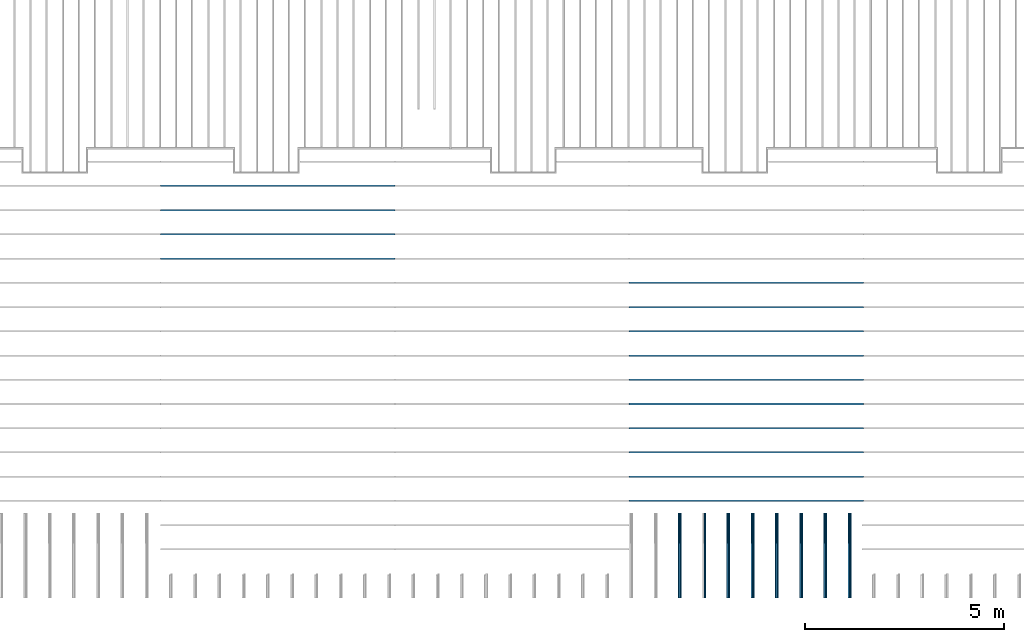
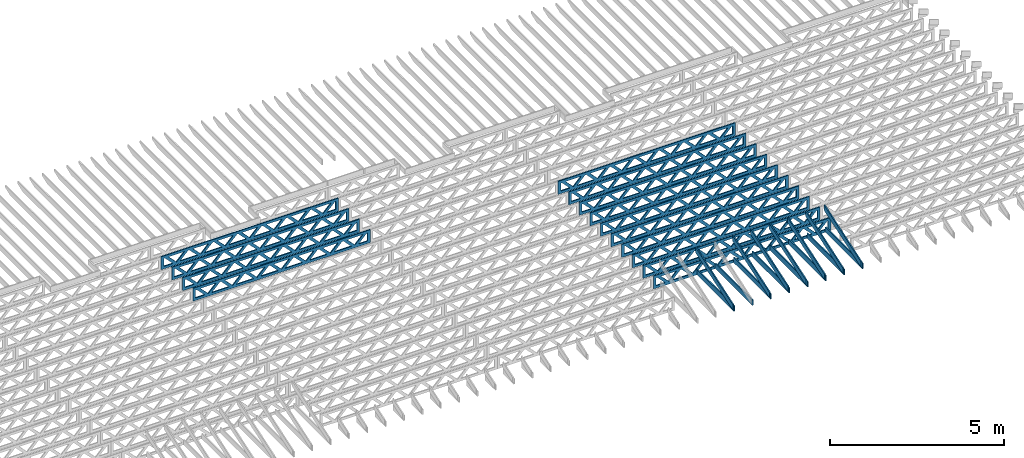
# One storey, part 8 of 18: 29 beams, 4 elements without a shape of their own.
"""IFC4 building model written with IfcOpenShell, lengths in feet."""

from ifc_helpers import new_model, entity, si_unit, converted_unit, derived_unit, direction, frame, frame_2d, origin, origin_2d_with_axis, place, context, subcontext, project, spatial, rectangle, extrude, clip, halfspace, source, transform, mapped, material, material_profile, profile_set, profile_usage, type_object, type_shapes, element, aggregate, save


model = new_model("IFC4")

# Units and contexts
model_context_1 = context("Model", 3, precision=0.0001, world=origin(), true_north=direction((6.12303176911189e-17, 1.0)))
model_context_2 = context("Model", 3, precision=0.0001, world=origin(), true_north=direction((6.12303176911189e-17, 1.0)))
body_context = subcontext(model_context_2, "Body", "Model", "MODEL_VIEW")
ifc_project = project(units=[converted_unit("LENGTHUNIT", "FOOT", entity("IfcRatioMeasure", 0.3048), si_unit("LENGTHUNIT", "METRE"), dimensions=[1, 0, 0, 0, 0, 0, 0]), converted_unit("AREAUNIT", "SQUARE FOOT", entity("IfcRatioMeasure", 0.09290304), si_unit("AREAUNIT", "SQUARE_METRE"), dimensions=[2, 0, 0, 0, 0, 0, 0]), converted_unit("VOLUMEUNIT", "CUBIC FOOT", entity("IfcRatioMeasure", 0.028316846592), si_unit("VOLUMEUNIT", "CUBIC_METRE"), dimensions=[3, 0, 0, 0, 0, 0, 0]), converted_unit("PLANEANGLEUNIT", "DEGREE", entity("IfcRatioMeasure", 0.0174532925199433), si_unit("PLANEANGLEUNIT", "RADIAN"), dimensions=[0, 0, 0, 0, 0, 0, 0]), si_unit("MASSUNIT", "GRAM", prefix="KILO"), derived_unit("MASSDENSITYUNIT", [(si_unit("MASSUNIT", "GRAM", prefix="KILO"), 1), (si_unit("LENGTHUNIT", "METRE"), -3)]), derived_unit("MOMENTOFINERTIAUNIT", [(si_unit("LENGTHUNIT", "METRE"), 4)]), si_unit("TIMEUNIT", "SECOND"), si_unit("FREQUENCYUNIT", "HERTZ"), si_unit("THERMODYNAMICTEMPERATUREUNIT", "DEGREE_CELSIUS"), derived_unit("THERMALTRANSMITTANCEUNIT", [(si_unit("MASSUNIT", "GRAM", prefix="KILO"), 1), (si_unit("THERMODYNAMICTEMPERATUREUNIT", "KELVIN"), -1), (si_unit("TIMEUNIT", "SECOND"), -3)]), derived_unit("VOLUMETRICFLOWRATEUNIT", [(si_unit("LENGTHUNIT", "METRE"), 3), (si_unit("TIMEUNIT", "SECOND"), -1)]), si_unit("ELECTRICCURRENTUNIT", "AMPERE"), si_unit("ELECTRICVOLTAGEUNIT", "VOLT"), si_unit("POWERUNIT", "WATT"), si_unit("FORCEUNIT", "NEWTON"), si_unit("ILLUMINANCEUNIT", "LUX"), si_unit("LUMINOUSFLUXUNIT", "LUMEN"), si_unit("LUMINOUSINTENSITYUNIT", "CANDELA"), derived_unit("USERDEFINED", [(si_unit("MASSUNIT", "GRAM", prefix="KILO"), -1), (si_unit("LENGTHUNIT", "METRE"), -2), (si_unit("TIMEUNIT", "SECOND"), 3), (si_unit("LUMINOUSFLUXUNIT", "LUMEN"), 1)]), derived_unit("LINEARVELOCITYUNIT", [(si_unit("LENGTHUNIT", "METRE"), 1), (si_unit("TIMEUNIT", "SECOND"), -1)]), si_unit("PRESSUREUNIT", "PASCAL"), derived_unit("USERDEFINED", [(si_unit("LENGTHUNIT", "METRE"), -2), (si_unit("MASSUNIT", "GRAM", prefix="KILO"), 1), (si_unit("TIMEUNIT", "SECOND"), -2)]), derived_unit("LINEARFORCEUNIT", [(si_unit("MASSUNIT", "GRAM", prefix="KILO"), 1), (si_unit("LENGTHUNIT", "METRE"), 1), (si_unit("TIMEUNIT", "SECOND"), -2), (si_unit("LENGTHUNIT", "METRE"), -1)]), derived_unit("PLANARFORCEUNIT", [(si_unit("MASSUNIT", "GRAM", prefix="KILO"), 1), (si_unit("LENGTHUNIT", "METRE"), 1), (si_unit("TIMEUNIT", "SECOND"), -2), (si_unit("LENGTHUNIT", "METRE"), -2)])], contexts=[model_context_1])

# Site, building, storey
site_placement = place(None, origin())
site = spatial("IfcSite", under=ifc_project, at=site_placement, CompositionType="ELEMENT")
building_placement = place(site_placement, origin())
building = spatial("IfcBuilding", under=site, at=building_placement, CompositionType="ELEMENT")
storey_placement = place(building_placement, frame((0.0, 0.0, 30.4375000000082)))
storey = spatial("IfcBuildingStorey", under=building, at=storey_placement, Name="ROOF", CompositionType="ELEMENT", Elevation=30.4375000000082)

# Assembly, beams
assembly_1_placement = place(storey_placement, origin())
assembly_1 = element("IfcElementAssembly", 1, at=assembly_1_placement, inside=storey, Name="Structural Beam System:Structural Framing System", ObjectType="Structural Beam System:Structural Framing System", AssemblyPlace="NOTDEFINED", PredefinedType="BEAM_GRID")
ifc_material_1 = material(Name="TOP CHORD OF FIELD FRAMED OVERHANG", Category="Materials")
ifc_material_profile_1 = material_profile(ifc_material_1, rectangle(XDim=0.604166666666667, YDim=0.125, at=origin_2d_with_axis()), Name="2X8 TOP CHORD")
ifc_profile_set_1 = profile_set([ifc_material_profile_1], Name="2X8 TOP CHORD")
ifc_profile_usage_1 = profile_usage(ifc_profile_set_1, cardinal=8)
beam_type_1 = type_object("IfcBeamType", Name="Dimension Lumber - Ends:2X8 TOP CHORD", PredefinedType="BEAM", material=ifc_profile_set_1)
shared_shape_1 = source(origin(), body_context, "Body", "Clipping", [
    clip(clip(extrude(rectangle(XDim=0.604166666666667, YDim=0.125, at=origin_2d_with_axis()), frame((-3.68931731846402, 0.0, 0.0), z_axis=(1.0, 0.0, 0.0), x_axis=(0.0, 0.0, -1.0)), (0.0, 0.0, 1.0), 7.5799655454405), halfspace(frame((3.68931731846399, -0.0625000000000025, -0.302083333333339), z_axis=(0.948710608132914, 0.0, -0.316145823973806), x_axis=(0.0, 1.0, 0.0)), False)), halfspace(frame((-3.48798640995154, -0.0625000000000025, 0.302083333333328), z_axis=(-0.948710608132914, 0.0, 0.316145823973807), x_axis=(0.0, 1.0, 0.0)), False)),
])
type_shapes(beam_type_1, [shared_shape_1])
beam_1_placement = place(assembly_1_placement, frame((-173.613158541547, 925.266385711858, 2.4368854134562), z_axis=(0.0, -0.316227766016849, 0.94868329805051), x_axis=(0.0, 0.94868329805051, 0.316227766016849)))
beam_1 = element("IfcBeam", 2, at=beam_1_placement, type_object=beam_type_1, material=ifc_profile_usage_1, Name="Dimension Lumber - Ends:2X8 TOP CHORD", ObjectType="Dimension Lumber - Ends:2X8 TOP CHORD", PredefinedType="BEAM", context=body_context, shape_type="MappedRepresentation", body=[
    mapped(shared_shape_1, transform((0.0, 0.0, 0.0), scale=1.0)),
])
ifc_profile_usage_2 = profile_usage(ifc_profile_set_1, cardinal=8)
beam_2_placement = place(assembly_1_placement, frame((-169.613158541547, 925.266385711858, 2.43688541345608), z_axis=(0.0, -0.316227766016849, 0.94868329805051), x_axis=(0.0, 0.94868329805051, 0.316227766016849)))
beam_2 = element("IfcBeam", 3, at=beam_2_placement, type_object=beam_type_1, material=ifc_profile_usage_2, Name="Dimension Lumber - Ends:2X8 TOP CHORD", ObjectType="Dimension Lumber - Ends:2X8 TOP CHORD", PredefinedType="BEAM", context=body_context, shape_type="MappedRepresentation", body=[
    mapped(shared_shape_1, transform((0.0, 0.0, 0.0), scale=1.0)),
])
ifc_profile_usage_3 = profile_usage(ifc_profile_set_1, cardinal=8)
beam_3_placement = place(assembly_1_placement, frame((-165.613158541547, 925.266385711858, 2.43688541345608), z_axis=(0.0, -0.31622776601685, 0.94868329805051), x_axis=(0.0, 0.94868329805051, 0.31622776601685)))
beam_3 = element("IfcBeam", 4, at=beam_3_placement, type_object=beam_type_1, material=ifc_profile_usage_3, Name="Dimension Lumber - Ends:2X8 TOP CHORD", ObjectType="Dimension Lumber - Ends:2X8 TOP CHORD", PredefinedType="BEAM", context=body_context, shape_type="MappedRepresentation", body=[
    mapped(shared_shape_1, transform((0.0, 0.0, 0.0), scale=1.0)),
])
ifc_profile_usage_4 = profile_usage(ifc_profile_set_1, cardinal=8)
beam_4_placement = place(assembly_1_placement, frame((-167.613158541547, 925.266385711858, 2.43688541345608), z_axis=(0.0, -0.316227766016849, 0.94868329805051), x_axis=(0.0, 0.94868329805051, 0.316227766016849)))
beam_4 = element("IfcBeam", 5, at=beam_4_placement, type_object=beam_type_1, material=ifc_profile_usage_4, Name="Dimension Lumber - Ends:2X8 TOP CHORD", ObjectType="Dimension Lumber - Ends:2X8 TOP CHORD", PredefinedType="BEAM", context=body_context, shape_type="MappedRepresentation", body=[
    mapped(shared_shape_1, transform((0.0, 0.0, 0.0), scale=1.0)),
])
ifc_profile_usage_5 = profile_usage(ifc_profile_set_1, cardinal=8)
beam_5_placement = place(assembly_1_placement, frame((-171.613158541547, 925.266385711858, 2.43688541345614), z_axis=(0.0, -0.31622776601685, 0.94868329805051), x_axis=(0.0, 0.94868329805051, 0.31622776601685)))
beam_5 = element("IfcBeam", 6, at=beam_5_placement, type_object=beam_type_1, material=ifc_profile_usage_5, Name="Dimension Lumber - Ends:2X8 TOP CHORD", ObjectType="Dimension Lumber - Ends:2X8 TOP CHORD", PredefinedType="BEAM", context=body_context, shape_type="MappedRepresentation", body=[
    mapped(shared_shape_1, transform((0.0, 0.0, 0.0), scale=1.0)),
])
ifc_profile_usage_6 = profile_usage(ifc_profile_set_1, cardinal=8)
beam_6_placement = place(assembly_1_placement, frame((-175.613158541547, 925.266385711858, 2.43688541345614), z_axis=(0.0, -0.316227766016849, 0.94868329805051), x_axis=(0.0, 0.94868329805051, 0.316227766016849)))
beam_6 = element("IfcBeam", 7, at=beam_6_placement, type_object=beam_type_1, material=ifc_profile_usage_6, Name="Dimension Lumber - Ends:2X8 TOP CHORD", ObjectType="Dimension Lumber - Ends:2X8 TOP CHORD", PredefinedType="BEAM", context=body_context, shape_type="MappedRepresentation", body=[
    mapped(shared_shape_1, transform((0.0, 0.0, 0.0), scale=1.0)),
])
ifc_profile_usage_7 = profile_usage(ifc_profile_set_1, cardinal=8)
beam_7_placement = place(assembly_1_placement, frame((-179.613158541548, 925.266385711858, 2.4368854134562), z_axis=(0.0, -0.316227766016853, 0.948683298050509), x_axis=(0.0, 0.948683298050509, 0.316227766016853)))
beam_7 = element("IfcBeam", 8, at=beam_7_placement, type_object=beam_type_1, material=ifc_profile_usage_7, Name="Dimension Lumber - Ends:2X8 TOP CHORD", ObjectType="Dimension Lumber - Ends:2X8 TOP CHORD", PredefinedType="BEAM", context=body_context, shape_type="MappedRepresentation", body=[
    mapped(shared_shape_1, transform((0.0, 0.0, 0.0), scale=1.0)),
])
aggregate(assembly_1, [beam_1, beam_2, beam_3, beam_4, beam_5, beam_6, beam_7])

assembly_2_placement = place(storey_placement, origin())
assembly_2 = element("IfcElementAssembly", 9, at=assembly_2_placement, inside=storey, Name="Structural Beam System:Structural Framing System", ObjectType="Structural Beam System:Structural Framing System", AssemblyPlace="NOTDEFINED", PredefinedType="BEAM_GRID")
ifc_material_2 = material(Name="BOTTOM CHORD OF FIELD FRAMED OVERHANG", Category="Materials")
ifc_material_profile_2 = material_profile(ifc_material_2, rectangle(XDim=0.604166666666667, YDim=0.125000000000011, at=origin_2d_with_axis()), Name="2X8 - BOTTOM CHORD")
ifc_profile_set_2 = profile_set([ifc_material_profile_2], Name="2X8 - BOTTOM CHORD")
ifc_profile_usage_8 = profile_usage(ifc_profile_set_2, cardinal=8)
beam_type_2 = type_object("IfcBeamType", Name="061100 - Wood Framing:2X8 - BOTTOM CHORD", PredefinedType="BEAM", material=ifc_profile_set_2)
shared_shape_2 = source(origin(), body_context, "Body", "SweptSolid", [
    extrude(rectangle(XDim=0.604166666666667, YDim=0.125000000000011, at=origin_2d_with_axis()), frame((-3.49999999999926, 0.0, 0.0), z_axis=(1.0, 0.0, 0.0), x_axis=(0.0, 0.0, -1.0)), (0.0, 0.0, 1.0), 6.99999999999852),
])
type_shapes(beam_type_2, [shared_shape_2])
beam_8_placement = place(assembly_2_placement, frame((-179.488158437574, 925.361940807891, 1.07291666665406), z_axis=(0.0, 0.0, 1.0), x_axis=(0.0, -1.0, 0.0)))
beam_8 = element("IfcBeam", 10, at=beam_8_placement, type_object=beam_type_2, material=ifc_profile_usage_8, Name="061100 - Wood Framing:2X8 - BOTTOM CHORD", ObjectType="061100 - Wood Framing:2X8 - BOTTOM CHORD", PredefinedType="BEAM", context=body_context, shape_type="MappedRepresentation", body=[
    mapped(shared_shape_2, transform((0.0, 0.0, 0.0), scale=1.0)),
])
ifc_profile_usage_9 = profile_usage(ifc_profile_set_2, cardinal=8)
beam_9_placement = place(assembly_2_placement, frame((-175.488158437574, 925.361941812898, 1.07291666665406), z_axis=(0.0, 0.0, 1.0), x_axis=(0.0, -1.0, 0.0)))
beam_9 = element("IfcBeam", 11, at=beam_9_placement, type_object=beam_type_2, material=ifc_profile_usage_9, Name="061100 - Wood Framing:2X8 - BOTTOM CHORD", ObjectType="061100 - Wood Framing:2X8 - BOTTOM CHORD", PredefinedType="BEAM", context=body_context, shape_type="MappedRepresentation", body=[
    mapped(shared_shape_2, transform((0.0, 0.0, 0.0), scale=1.0)),
])
ifc_profile_usage_10 = profile_usage(ifc_profile_set_2, cardinal=8)
beam_10_placement = place(assembly_2_placement, frame((-173.488158437574, 925.361942315402, 1.07291666665406), z_axis=(0.0, 0.0, 1.0), x_axis=(0.0, -1.0, 0.0)))
beam_10 = element("IfcBeam", 12, at=beam_10_placement, type_object=beam_type_2, material=ifc_profile_usage_10, Name="061100 - Wood Framing:2X8 - BOTTOM CHORD", ObjectType="061100 - Wood Framing:2X8 - BOTTOM CHORD", PredefinedType="BEAM", context=body_context, shape_type="MappedRepresentation", body=[
    mapped(shared_shape_2, transform((0.0, 0.0, 0.0), scale=1.0)),
])
ifc_profile_usage_11 = profile_usage(ifc_profile_set_2, cardinal=8)
beam_11_placement = place(assembly_2_placement, frame((-171.488158437574, 925.361942817905, 1.07291666665406), z_axis=(0.0, 0.0, 1.0), x_axis=(0.0, -1.0, 0.0)))
beam_11 = element("IfcBeam", 13, at=beam_11_placement, type_object=beam_type_2, material=ifc_profile_usage_11, Name="061100 - Wood Framing:2X8 - BOTTOM CHORD", ObjectType="061100 - Wood Framing:2X8 - BOTTOM CHORD", PredefinedType="BEAM", context=body_context, shape_type="MappedRepresentation", body=[
    mapped(shared_shape_2, transform((0.0, 0.0, 0.0), scale=1.0)),
])
ifc_profile_usage_12 = profile_usage(ifc_profile_set_2, cardinal=8)
beam_12_placement = place(assembly_2_placement, frame((-165.488158437574, 925.361944325417, 1.07291666665406), z_axis=(0.0, 0.0, 1.0), x_axis=(0.0, -1.0, 0.0)))
beam_12 = element("IfcBeam", 14, at=beam_12_placement, type_object=beam_type_2, material=ifc_profile_usage_12, Name="061100 - Wood Framing:2X8 - BOTTOM CHORD", ObjectType="061100 - Wood Framing:2X8 - BOTTOM CHORD", PredefinedType="BEAM", context=body_context, shape_type="MappedRepresentation", body=[
    mapped(shared_shape_2, transform((0.0, 0.0, 0.0), scale=1.0)),
])
ifc_profile_usage_13 = profile_usage(ifc_profile_set_2, cardinal=8)
beam_13_placement = place(assembly_2_placement, frame((-167.488158437574, 925.361943822913, 1.07291666665406), z_axis=(0.0, 0.0, 1.0), x_axis=(0.0, -1.0, 0.0)))
beam_13 = element("IfcBeam", 15, at=beam_13_placement, type_object=beam_type_2, material=ifc_profile_usage_13, Name="061100 - Wood Framing:2X8 - BOTTOM CHORD", ObjectType="061100 - Wood Framing:2X8 - BOTTOM CHORD", PredefinedType="BEAM", context=body_context, shape_type="MappedRepresentation", body=[
    mapped(shared_shape_2, transform((0.0, 0.0, 0.0), scale=1.0)),
])
ifc_profile_usage_14 = profile_usage(ifc_profile_set_2, cardinal=8)
beam_14_placement = place(assembly_2_placement, frame((-169.488158437574, 925.361943320409, 1.07291666665406), z_axis=(0.0, 0.0, 1.0), x_axis=(0.0, -1.0, 0.0)))
beam_14 = element("IfcBeam", 16, at=beam_14_placement, type_object=beam_type_2, material=ifc_profile_usage_14, Name="061100 - Wood Framing:2X8 - BOTTOM CHORD", ObjectType="061100 - Wood Framing:2X8 - BOTTOM CHORD", PredefinedType="BEAM", context=body_context, shape_type="MappedRepresentation", body=[
    mapped(shared_shape_2, transform((0.0, 0.0, 0.0), scale=1.0)),
])
ifc_profile_usage_15 = profile_usage(ifc_profile_set_2, cardinal=8)
beam_15_placement = place(assembly_2_placement, frame((-177.488158437574, 925.361941310394, 1.07291666665406), z_axis=(0.0, 0.0, 1.0), x_axis=(0.0, -1.0, 0.0)))
beam_15 = element("IfcBeam", 17, at=beam_15_placement, type_object=beam_type_2, material=ifc_profile_usage_15, Name="061100 - Wood Framing:2X8 - BOTTOM CHORD", ObjectType="061100 - Wood Framing:2X8 - BOTTOM CHORD", PredefinedType="BEAM", context=body_context, shape_type="MappedRepresentation", body=[
    mapped(shared_shape_2, transform((0.0, 0.0, 0.0), scale=1.0)),
])
aggregate(assembly_2, [beam_8, beam_9, beam_10, beam_11, beam_12, beam_13, beam_14, beam_15])

assembly_3_placement = place(storey_placement, origin())
assembly_3 = element("IfcElementAssembly", 18, at=assembly_3_placement, inside=storey, Name="Structural Beam System:Structural Framing System", ObjectType="Structural Beam System:Structural Framing System", AssemblyPlace="NOTDEFINED", PredefinedType="BEAM_GRID")
ifc_material_3 = material(Name="WOOD TRUSS", Category="Materials")
ifc_material_profile_3 = material_profile(ifc_material_3, rectangle(XDim=1.73473973950632, YDim=0.125, at=origin_2d_with_axis()))
ifc_material_profile_4 = material_profile(ifc_material_3, rectangle(XDim=1.73473973950633, YDim=0.125, at=frame_2d((-1.11022302462516e-16, 0.0), x_axis=(1.0, 0.0))))
ifc_material_profile_5 = material_profile(ifc_material_3, rectangle(XDim=1.73473973950632, YDim=0.125, at=origin_2d_with_axis()))
ifc_material_profile_6 = material_profile(ifc_material_3, rectangle(XDim=1.73473973950633, YDim=0.125, at=origin_2d_with_axis()))
ifc_material_profile_7 = material_profile(ifc_material_3, rectangle(XDim=1.73473973950632, YDim=0.125, at=frame_2d((-5.55111512312578e-17, 0.0), x_axis=(1.0, 0.0))))
ifc_material_profile_8 = material_profile(ifc_material_3, rectangle(XDim=1.73473973950633, YDim=0.125, at=frame_2d((-2.77555756156289e-16, 0.0), x_axis=(1.0, 0.0))))
ifc_material_profile_9 = material_profile(ifc_material_3, rectangle(XDim=1.73473973950632, YDim=0.125, at=frame_2d((-4.9960036108132e-16, 0.0), x_axis=(1.0, 0.0))))
ifc_material_profile_10 = material_profile(ifc_material_3, rectangle(XDim=1.73473973950633, YDim=0.125, at=frame_2d((4.44089209850063e-16, 0.0), x_axis=(1.0, 0.0))))
ifc_material_profile_11 = material_profile(ifc_material_3, rectangle(XDim=1.73473973950632, YDim=0.125, at=origin_2d_with_axis()))
ifc_material_profile_12 = material_profile(ifc_material_3, rectangle(XDim=1.73473973950633, YDim=0.125, at=frame_2d((-4.9960036108132e-16, 0.0), x_axis=(1.0, 0.0))))
ifc_material_profile_13 = material_profile(ifc_material_3, rectangle(XDim=0.291666666666664, YDim=0.125, at=frame_2d((-2.77555756156289e-17, 0.0), x_axis=(1.0, 0.0))))
ifc_material_profile_14 = material_profile(ifc_material_3, rectangle(XDim=0.291666666666628, YDim=0.124999999999995, at=frame_2d((-5.55111512312578e-17, 0.0), x_axis=(1.0, 0.0))))
ifc_material_profile_15 = material_profile(ifc_material_3, rectangle(XDim=0.916666666666666, YDim=0.125000000000003, at=frame_2d((-2.77555756156289e-17, 0.0), x_axis=(1.0, 0.0))))
ifc_material_profile_16 = material_profile(ifc_material_3, rectangle(XDim=0.916666666666651, YDim=0.125, at=frame_2d((-2.77555756156289e-17, 0.0), x_axis=(1.0, 0.0))))
ifc_profile_set_3 = profile_set([ifc_material_profile_3, ifc_material_profile_4, ifc_material_profile_5, ifc_material_profile_6, ifc_material_profile_7, ifc_material_profile_8, ifc_material_profile_9, ifc_material_profile_10, ifc_material_profile_11, ifc_material_profile_12, ifc_material_profile_13, ifc_material_profile_14, ifc_material_profile_15, ifc_material_profile_16])
ifc_profile_usage_16 = profile_usage(ifc_profile_set_3, cardinal=8)
beam_type_3 = type_object("IfcBeamType", PredefinedType="BEAM", material=ifc_profile_set_3)
shared_shape_3 = source(origin(), body_context, "Body", "SweptSolid", [
    extrude(rectangle(XDim=1.73473973950632, YDim=0.125, at=frame_2d((-5.55111512312578e-16, 0.0), x_axis=(1.0, 0.0))), frame((5.85339326404794, 0.0, 0.101118361020562), z_axis=(0.720569184836762, 0.0, -0.693383046997606), x_axis=(0.693383046997606, 0.0, 0.720569184836762)), (0.0, 0.0, 1.0), 0.291666666666667),
    extrude(rectangle(XDim=1.73473973950633, YDim=0.125, at=frame_2d((-4.9960036108132e-16, 0.0), x_axis=(1.0, 0.0))), frame((4.60310739037467, 0.0, -0.101118361020407), z_axis=(0.720569184836758, 0.0, 0.69338304699761), x_axis=(0.69338304699761, 0.0, -0.720569184836758)), (0.0, 0.0, 1.0), 0.291666666666667),
    extrude(rectangle(XDim=1.73473973950632, YDim=0.125, at=frame_2d((3.33066907387547e-16, 0.0), x_axis=(1.0, 0.0))), frame((3.18672659738144, 0.0, 0.101118361020562), z_axis=(0.720569184836762, 0.0, -0.693383046997606), x_axis=(0.693383046997606, 0.0, 0.720569184836762)), (0.0, 0.0, 1.0), 0.291666666666667),
    extrude(rectangle(XDim=1.73473973950633, YDim=0.125, at=frame_2d((-1.11022302462516e-16, 0.0), x_axis=(1.0, 0.0))), frame((1.93644072370817, 0.0, -0.101118361020407), z_axis=(0.720569184836758, 0.0, 0.69338304699761), x_axis=(0.69338304699761, 0.0, -0.720569184836758)), (0.0, 0.0, 1.0), 0.291666666666666),
    extrude(rectangle(XDim=1.73473973950632, YDim=0.125, at=frame_2d((5.55111512312578e-17, 0.0), x_axis=(1.0, 0.0))), frame((0.520059930714937, 0.0, 0.101118361020562), z_axis=(0.720569184836762, 0.0, -0.693383046997606), x_axis=(0.693383046997606, 0.0, 0.720569184836762)), (0.0, 0.0, 1.0), 0.291666666666667),
    extrude(rectangle(XDim=1.73473973950633, YDim=0.125, at=origin_2d_with_axis()), frame((-0.730225942958334, 0.0, -0.101118361020407), z_axis=(0.720569184836758, 0.0, 0.69338304699761), x_axis=(0.69338304699761, 0.0, -0.720569184836758)), (0.0, 0.0, 1.0), 0.291666666666666),
    extrude(rectangle(XDim=1.73473973950632, YDim=0.125, at=frame_2d((-5.55111512312578e-17, 0.0), x_axis=(1.0, 0.0))), frame((-2.14660673595157, 0.0, 0.101118361020562), z_axis=(0.720569184836762, 0.0, -0.693383046997606), x_axis=(0.693383046997606, 0.0, 0.720569184836762)), (0.0, 0.0, 1.0), 0.291666666666667),
    extrude(rectangle(XDim=1.73473973950633, YDim=0.125, at=frame_2d((-2.77555756156289e-16, 0.0), x_axis=(1.0, 0.0))), frame((-3.39689260962484, 0.0, -0.101118361020407), z_axis=(0.720569184836758, 0.0, 0.69338304699761), x_axis=(0.69338304699761, 0.0, -0.720569184836758)), (0.0, 0.0, 1.0), 0.291666666666666),
    extrude(rectangle(XDim=1.73473973950632, YDim=0.125, at=origin_2d_with_axis()), frame((-4.81327340261807, 0.0, 0.101118361020562), z_axis=(0.720569184836762, 0.0, -0.693383046997606), x_axis=(0.693383046997606, 0.0, 0.720569184836762)), (0.0, 0.0, 1.0), 0.291666666666667),
    extrude(rectangle(XDim=1.73473973950633, YDim=0.125, at=frame_2d((-4.9960036108132e-16, 0.0), x_axis=(1.0, 0.0))), frame((-6.06355927629134, 0.0, -0.101118361020407), z_axis=(0.720569184836758, 0.0, 0.69338304699761), x_axis=(0.69338304699761, 0.0, -0.720569184836758)), (0.0, 0.0, 1.0), 0.291666666666667),
    extrude(rectangle(XDim=1.73473973950632, YDim=0.125, at=frame_2d((-1.0547118733939e-15, 0.0), x_axis=(1.0, 0.0))), frame((8.52005993071445, 0.0, 0.101118361020506), z_axis=(0.720569184836761, 0.0, -0.693383046997607), x_axis=(0.693383046997607, 0.0, 0.720569184836761)), (0.0, 0.0, 1.0), 0.291666666666667),
    extrude(rectangle(XDim=1.73473973950633, YDim=0.125, at=origin_2d_with_axis()), frame((7.26977405704118, 0.0, -0.101118361020463), z_axis=(0.720569184836758, 0.0, 0.69338304699761), x_axis=(0.69338304699761, 0.0, -0.720569184836758)), (0.0, 0.0, 1.0), 0.291666666666667),
    extrude(rectangle(XDim=1.73473973950632, YDim=0.125, at=frame_2d((4.44089209850063e-16, 0.0), x_axis=(1.0, 0.0))), frame((-7.47994006928457, 0.0, 0.101118361020561), z_axis=(0.720569184836762, 0.0, -0.693383046997606), x_axis=(0.693383046997606, 0.0, 0.720569184836762)), (0.0, 0.0, 1.0), 0.291666666666666),
    extrude(rectangle(XDim=1.73473973950633, YDim=0.125, at=origin_2d_with_axis()), frame((-8.73022594295784, 0.0, -0.101118361020408), z_axis=(0.720569184836758, 0.0, 0.69338304699761), x_axis=(0.69338304699761, 0.0, -0.720569184836758)), (0.0, 0.0, 1.0), 0.291666666666666),
    extrude(rectangle(XDim=0.291666666666664, YDim=0.125, at=frame_2d((-2.77555756156289e-17, 0.0), x_axis=(1.0, 0.0))), frame((-9.66666666666609, 0.0, 0.604166666666611), z_axis=(1.0, 0.0, 0.0), x_axis=(0.0, 0.0, -1.0)), (0.0, 0.0, 1.0), 19.3333333333322),
    extrude(rectangle(XDim=0.291666666666628, YDim=0.124999999999995, at=frame_2d((-5.55111512312578e-17, 0.0), x_axis=(1.0, 0.0))), frame((-9.66666666666588, 0.0, -0.604166666666693), z_axis=(1.0, 0.0, 0.0), x_axis=(0.0, 0.0, -1.0)), (0.0, 0.0, 1.0), 19.333333333332),
    extrude(rectangle(XDim=0.916666666666666, YDim=0.125000000000003, at=frame_2d((-2.77555756156289e-17, 0.0), x_axis=(1.0, 0.0))), frame((9.3749999999994, 0.0, 0.0), z_axis=(1.0, 0.0, 0.0), x_axis=(0.0, 0.0, -1.0)), (0.0, 0.0, 1.0), 0.291666666666687),
    extrude(rectangle(XDim=0.916666666666651, YDim=0.125, at=frame_2d((-2.77555756156289e-17, 0.0), x_axis=(1.0, 0.0))), frame((-9.66666666666609, 0.0, 0.0), z_axis=(1.0, 0.0, 0.0), x_axis=(0.0, 0.0, -1.0)), (0.0, 0.0, 1.0), 0.291666666666687),
])
type_shapes(beam_type_3, [shared_shape_3])
beam_16_placement = place(assembly_3_placement, frame((-212.738160485494, 949.861934882651, 0.749999999991616), z_axis=(0.0, 0.0, 1.0), x_axis=(-1.0, 0.0, 0.0)))
beam_16 = element("IfcBeam", 19, at=beam_16_placement, type_object=beam_type_3, material=ifc_profile_usage_16, PredefinedType="BEAM", context=body_context, shape_type="MappedRepresentation", body=[
    mapped(shared_shape_3, transform((0.0, 0.0, 0.0), scale=1.0)),
])
ifc_profile_usage_17 = profile_usage(ifc_profile_set_3, cardinal=8)
beam_17_placement = place(assembly_3_placement, frame((-212.738160485494, 951.861934882651, 0.749999999991608), z_axis=(0.0, 0.0, 1.0), x_axis=(-1.0, 0.0, 0.0)))
beam_17 = element("IfcBeam", 20, at=beam_17_placement, type_object=beam_type_3, material=ifc_profile_usage_17, PredefinedType="BEAM", context=body_context, shape_type="MappedRepresentation", body=[
    mapped(shared_shape_3, transform((0.0, 0.0, 0.0), scale=1.0)),
])
ifc_profile_usage_18 = profile_usage(ifc_profile_set_3, cardinal=8)
beam_18_placement = place(assembly_3_placement, frame((-212.738160485494, 953.861934882651, 0.749999999991601), z_axis=(0.0, 0.0, 1.0), x_axis=(-1.0, 0.0, 0.0)))
beam_18 = element("IfcBeam", 21, at=beam_18_placement, type_object=beam_type_3, material=ifc_profile_usage_18, PredefinedType="BEAM", context=body_context, shape_type="MappedRepresentation", body=[
    mapped(shared_shape_3, transform((0.0, 0.0, 0.0), scale=1.0)),
])
ifc_profile_usage_19 = profile_usage(ifc_profile_set_3, cardinal=8)
beam_19_placement = place(assembly_3_placement, frame((-212.738160485494, 955.861934882651, 0.749999999991601), z_axis=(0.0, 0.0, 1.0), x_axis=(-1.0, 0.0, 0.0)))
beam_19 = element("IfcBeam", 22, at=beam_19_placement, type_object=beam_type_3, material=ifc_profile_usage_19, PredefinedType="BEAM", context=body_context, shape_type="MappedRepresentation", body=[
    mapped(shared_shape_3, transform((0.0, 0.0, 0.0), scale=1.0)),
])
aggregate(assembly_3, [beam_16, beam_17, beam_18, beam_19])

assembly_4_placement = place(storey_placement, origin())
assembly_4 = element("IfcElementAssembly", 23, at=assembly_4_placement, inside=storey, Name="Structural Beam System:Structural Framing System", ObjectType="Structural Beam System:Structural Framing System", AssemblyPlace="NOTDEFINED", PredefinedType="BEAM_GRID")
ifc_profile_usage_20 = profile_usage(ifc_profile_set_3, cardinal=8)
beam_20_placement = place(assembly_4_placement, frame((-174.071493818896, 929.861934882651, 0.74999999999168), z_axis=(0.0, 0.0, 1.0), x_axis=(-1.0, 0.0, 0.0)))
beam_20 = element("IfcBeam", 24, at=beam_20_placement, type_object=beam_type_3, material=ifc_profile_usage_20, PredefinedType="BEAM", context=body_context, shape_type="MappedRepresentation", body=[
    mapped(shared_shape_3, transform((0.0, 0.0, 0.0), scale=1.0)),
])
ifc_profile_usage_21 = profile_usage(ifc_profile_set_3, cardinal=8)
beam_21_placement = place(assembly_4_placement, frame((-174.071493818896, 931.861934882651, 0.74999999999168), z_axis=(0.0, 0.0, 1.0), x_axis=(-1.0, 0.0, 0.0)))
beam_21 = element("IfcBeam", 25, at=beam_21_placement, type_object=beam_type_3, material=ifc_profile_usage_21, PredefinedType="BEAM", context=body_context, shape_type="MappedRepresentation", body=[
    mapped(shared_shape_3, transform((0.0, 0.0, 0.0), scale=1.0)),
])
ifc_profile_usage_22 = profile_usage(ifc_profile_set_3, cardinal=8)
beam_22_placement = place(assembly_4_placement, frame((-174.071493818896, 933.861934882651, 0.749999999991672), z_axis=(0.0, 0.0, 1.0), x_axis=(-1.0, 0.0, 0.0)))
beam_22 = element("IfcBeam", 26, at=beam_22_placement, type_object=beam_type_3, material=ifc_profile_usage_22, PredefinedType="BEAM", context=body_context, shape_type="MappedRepresentation", body=[
    mapped(shared_shape_3, transform((0.0, 0.0, 0.0), scale=1.0)),
])
ifc_profile_usage_23 = profile_usage(ifc_profile_set_3, cardinal=8)
beam_23_placement = place(assembly_4_placement, frame((-174.071493818896, 935.861934882651, 0.749999999991665), z_axis=(0.0, 0.0, 1.0), x_axis=(-1.0, 0.0, 0.0)))
beam_23 = element("IfcBeam", 27, at=beam_23_placement, type_object=beam_type_3, material=ifc_profile_usage_23, PredefinedType="BEAM", context=body_context, shape_type="MappedRepresentation", body=[
    mapped(shared_shape_3, transform((0.0, 0.0, 0.0), scale=1.0)),
])
ifc_profile_usage_24 = profile_usage(ifc_profile_set_3, cardinal=8)
beam_24_placement = place(assembly_4_placement, frame((-174.071493818896, 937.861934882651, 0.749999999991658), z_axis=(0.0, 0.0, 1.0), x_axis=(-1.0, 0.0, 0.0)))
beam_24 = element("IfcBeam", 28, at=beam_24_placement, type_object=beam_type_3, material=ifc_profile_usage_24, PredefinedType="BEAM", context=body_context, shape_type="MappedRepresentation", body=[
    mapped(shared_shape_3, transform((0.0, 0.0, 0.0), scale=1.0)),
])
ifc_profile_usage_25 = profile_usage(ifc_profile_set_3, cardinal=8)
beam_25_placement = place(assembly_4_placement, frame((-174.071493818896, 939.861934882651, 0.749999999991651), z_axis=(0.0, 0.0, 1.0), x_axis=(-1.0, 0.0, 0.0)))
beam_25 = element("IfcBeam", 29, at=beam_25_placement, type_object=beam_type_3, material=ifc_profile_usage_25, PredefinedType="BEAM", context=body_context, shape_type="MappedRepresentation", body=[
    mapped(shared_shape_3, transform((0.0, 0.0, 0.0), scale=1.0)),
])
ifc_profile_usage_26 = profile_usage(ifc_profile_set_3, cardinal=8)
beam_26_placement = place(assembly_4_placement, frame((-174.071493818896, 943.861934882651, 0.749999999991644), z_axis=(0.0, 0.0, 1.0), x_axis=(-1.0, 0.0, 0.0)))
beam_26 = element("IfcBeam", 30, at=beam_26_placement, type_object=beam_type_3, material=ifc_profile_usage_26, PredefinedType="BEAM", context=body_context, shape_type="MappedRepresentation", body=[
    mapped(shared_shape_3, transform((0.0, 0.0, 0.0), scale=1.0)),
])
ifc_profile_usage_27 = profile_usage(ifc_profile_set_3, cardinal=8)
beam_27_placement = place(assembly_4_placement, frame((-174.071493818896, 947.861934882651, 0.74999999999163), z_axis=(0.0, 0.0, 1.0), x_axis=(-1.0, 0.0, 0.0)))
beam_27 = element("IfcBeam", 31, at=beam_27_placement, type_object=beam_type_3, material=ifc_profile_usage_27, PredefinedType="BEAM", context=body_context, shape_type="MappedRepresentation", body=[
    mapped(shared_shape_3, transform((0.0, 0.0, 0.0), scale=1.0)),
])
ifc_profile_usage_28 = profile_usage(ifc_profile_set_3, cardinal=8)
beam_28_placement = place(assembly_4_placement, frame((-174.071493818896, 945.861934882651, 0.749999999991637), z_axis=(0.0, 0.0, 1.0), x_axis=(-1.0, 0.0, 0.0)))
beam_28 = element("IfcBeam", 32, at=beam_28_placement, type_object=beam_type_3, material=ifc_profile_usage_28, PredefinedType="BEAM", context=body_context, shape_type="MappedRepresentation", body=[
    mapped(shared_shape_3, transform((0.0, 0.0, 0.0), scale=1.0)),
])
ifc_profile_usage_29 = profile_usage(ifc_profile_set_3, cardinal=8)
beam_29_placement = place(assembly_4_placement, frame((-174.071493818896, 941.861934882651, 0.749999999991651), z_axis=(0.0, 0.0, 1.0), x_axis=(-1.0, 0.0, 0.0)))
beam_29 = element("IfcBeam", 33, at=beam_29_placement, type_object=beam_type_3, material=ifc_profile_usage_29, PredefinedType="BEAM", context=body_context, shape_type="MappedRepresentation", body=[
    mapped(shared_shape_3, transform((0.0, 0.0, 0.0), scale=1.0)),
])
aggregate(assembly_4, [beam_20, beam_21, beam_22, beam_23, beam_24, beam_25, beam_26, beam_27, beam_28, beam_29])

save(model, "model.ifc")
